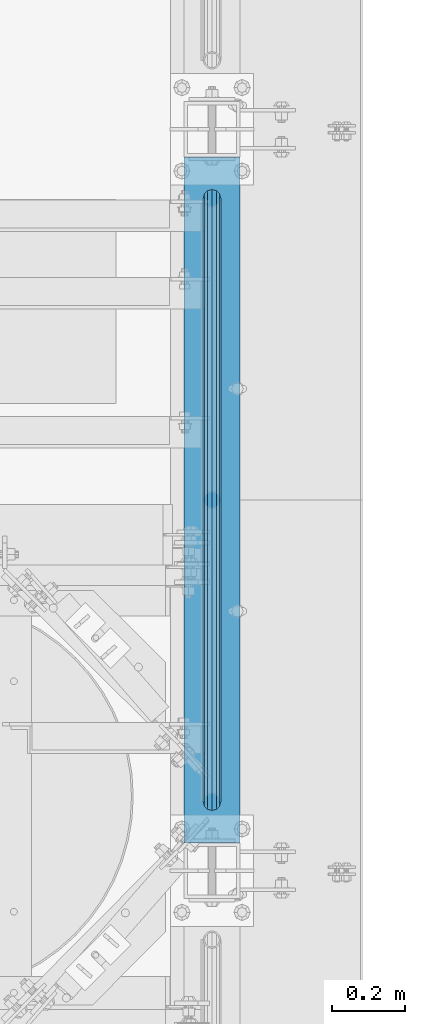
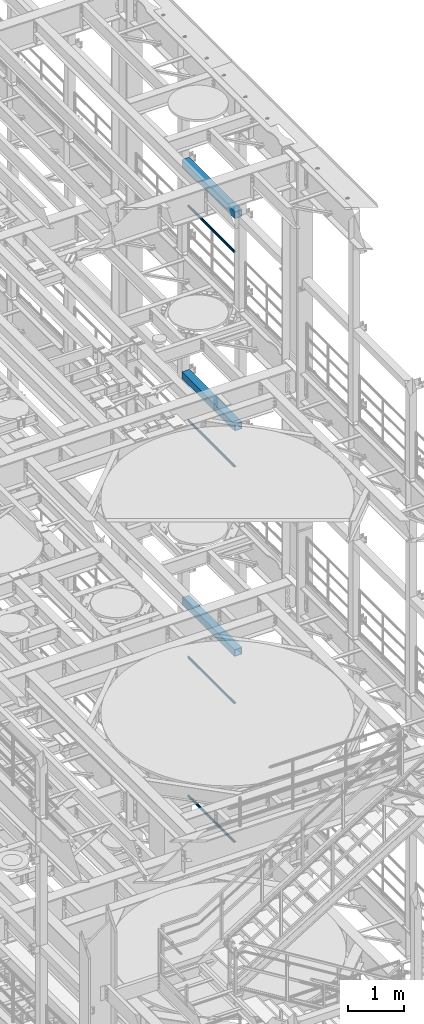
# One storey, part 1037 of 1876: 7 beams, 7 elements without a shape of their own.
"""IFC2X3 building model written with IfcOpenShell, lengths in millimetres."""

from ifc_helpers import new_model, si_unit, frame, origin_with_axes, place, context, subcontext, project, spatial, faceted_brep, material, type_object, element, aggregate, save


model = new_model("IFC2X3")

# Units and contexts
model_context = context("Model", 3, precision=1e-05, world=origin_with_axes())
body_context = subcontext(model_context, "Body", "Model", "MODEL_VIEW")
ifc_project = project(units=[si_unit("LENGTHUNIT", "METRE", prefix="MILLI"), si_unit("AREAUNIT", "SQUARE_METRE"), si_unit("VOLUMEUNIT", "CUBIC_METRE"), si_unit("MASSUNIT", "GRAM", prefix="KILO"), si_unit("TIMEUNIT", "SECOND"), si_unit("PLANEANGLEUNIT", "RADIAN"), si_unit("SOLIDANGLEUNIT", "STERADIAN"), si_unit("THERMODYNAMICTEMPERATUREUNIT", "DEGREE_CELSIUS"), si_unit("LUMINOUSINTENSITYUNIT", "LUMEN")], contexts=[model_context])

# Site, building, storey
site_placement = place(None, origin_with_axes())
site = spatial("IfcSite", under=ifc_project, at=site_placement, CompositionType="ELEMENT")
building_placement = place(site_placement, origin_with_axes())
building = spatial("IfcBuilding", under=site, at=building_placement, Name="Undefined", CompositionType="ELEMENT")
storey_placement = place(building_placement, origin_with_axes())
storey = spatial("IfcBuildingStorey", under=building, at=storey_placement, Name="Undefined", CompositionType="ELEMENT", Elevation=0.0)

# Assembly, beam
assembly_1_placement = place(storey_placement, origin_with_axes())
assembly_1 = element("IfcElementAssembly", 1, at=assembly_1_placement, inside=storey, Name="RAIL", AssemblyPlace="NOTDEFINED", PredefinedType="RIGID_FRAME")
ifc_material_1 = material()
beam_type_1 = type_object("IfcBeamType", Name="PIPE1-1/2SCH40", PredefinedType="NOTDEFINED")
beam_1_placement = place(assembly_1_placement, frame((7620.0, 3721.1, 19059.525), z_axis=(0.0, 0.0, -1.0), x_axis=(0.0, 1.0, 0.0)))
beam_1 = element("IfcBeam", 2, at=beam_1_placement, type_object=beam_type_1, material=ifc_material_1, Name="RAIL", ObjectType="PIPE1-1/2SCH40", context=body_context, shape_type="Brep", body=[
    faceted_brep([(24.1300000000001, -20.4469999999999, 0.0), (34.3535000000002, -17.7076214311803, 10.2235000000001), (1667.4465, -17.7076214311801, 10.2235000000001), (1677.67, -20.4470000000001, 0.0), (41.8376214311802, -10.2235000000001, 17.7076214311819), (1659.96237856882, -10.2235000000001, 17.7076214311819), (44.5770000000002, 0.0, 20.4470000000001), (1657.223, 0.0, 20.4470000000001), (41.8376214311802, 10.2235000000001, 17.7076214311819), (1659.96237856882, 10.2235000000001, 17.7076214311819), (34.3535000000002, 17.7076214311803, 10.2235000000001), (1667.4465, 17.7076214311801, 10.2235000000001), (24.1300000000001, 20.4469999999999, 0.0), (1677.67, 20.4470000000001, 0.0), (13.9065000000001, 17.7076214311803, -10.2235000000001), (1687.8935, 17.7076214311801, -10.2235000000001), (6.42237856882002, 10.2235000000001, -17.7076214311819), (1695.37762143118, 10.2235000000001, -17.7076214311819), (3.68299999999999, 0.0, -20.4470000000001), (1698.117, 0.0, -20.4470000000001), (6.42237856882002, -10.2235000000001, -17.7076214311819), (1695.37762143118, -10.2235000000001, -17.7076214311819), (13.9065000000001, -17.7076214311803, -10.2235000000001), (1687.8935, -17.7076214311801, -10.2235000000001), (24.1299999999854, -24.1299999999992, 0.0), (12.0650000000064, -20.8971929933177, -12.0649999999987), (1689.735, -20.8971929933186, -12.0649999999987), (1677.67, -24.1300000000001, 0.0), (3.23280700668147, -12.0650000000001, -20.8971929933177), (1698.56719299332, -12.0649999999996, -20.8971929933177), (-1.45519152283669e-11, 0.0, -24.130000000001), (1701.8, 0.0, -24.130000000001), (3.23280700668147, 12.0650000000001, -20.8971929933177), (1698.56719299332, 12.0649999999996, -20.8971929933177), (12.0650000000064, 20.8971929933177, -12.0649999999987), (1689.735, 20.8971929933186, -12.0649999999987), (24.1300000000047, 24.1299999999992, 0.0), (1677.67, 24.1300000000001, 0.0), (36.1949999999997, 20.8971929933184, 12.0649999999987), (1665.605, 20.8971929933186, 12.0649999999987), (45.0271929933187, 12.0650000000001, 20.8971929933177), (1656.77280700668, 12.0649999999996, 20.8971929933177), (48.2600000000002, 0.0, 24.130000000001), (1653.54, 0.0, 24.130000000001), (45.0271929933187, -12.0650000000001, 20.8971929933177), (1656.77280700668, -12.0649999999996, 20.8971929933177), (36.1949999999997, -20.8971929933184, 12.0649999999987), (1665.605, -20.8971929933186, 12.0649999999987)], [[[0, 1, 2, 3]], [[1, 4, 5, 2]], [[4, 6, 7, 5]], [[6, 8, 9, 7]], [[8, 10, 11, 9]], [[10, 12, 13, 11]], [[12, 14, 15, 13]], [[14, 16, 17, 15]], [[16, 18, 19, 17]], [[18, 20, 21, 19]], [[20, 22, 23, 21]], [[22, 0, 3, 23]], [[24, 25, 26, 27]], [[25, 28, 29, 26]], [[28, 30, 31, 29]], [[30, 32, 33, 31]], [[32, 34, 35, 33]], [[34, 36, 37, 35]], [[36, 38, 39, 37]], [[38, 40, 41, 39]], [[40, 42, 43, 41]], [[42, 44, 45, 43]], [[44, 46, 47, 45]], [[46, 24, 27, 47]], [[29, 31, 33, 35, 37, 39, 41, 43, 45, 47, 27, 26], [5, 7, 9, 11, 13, 15, 17, 19, 21, 23, 3, 2]], [[46, 44, 42, 40, 38, 36, 34, 32, 30, 28, 25, 24], [22, 20, 18, 16, 14, 12, 10, 8, 6, 4, 1, 0]]]),
])
aggregate(assembly_1, [beam_1])

assembly_2_placement = place(storey_placement, origin_with_axes())
assembly_2 = element("IfcElementAssembly", 3, at=assembly_2_placement, inside=storey, Name="RAIL", AssemblyPlace="NOTDEFINED", PredefinedType="RIGID_FRAME")
beam_2_placement = place(assembly_2_placement, frame((7620.0, 3721.1, 14385.925), z_axis=(0.0, 0.0, -1.0), x_axis=(0.0, 1.0, 0.0)))
beam_2 = element("IfcBeam", 4, at=beam_2_placement, type_object=beam_type_1, material=ifc_material_1, Name="RAIL", ObjectType="PIPE1-1/2SCH40", context=body_context, shape_type="Brep", body=[
    faceted_brep([(24.1300000000001, -20.4469999999999, 0.0), (34.3535000000002, -17.7076214311803, 10.2235000000001), (1667.4465, -17.7076214311801, 10.2235000000001), (1677.67, -20.4470000000001, 0.0), (41.8376214311802, -10.2235000000001, 17.7076214311819), (1659.96237856882, -10.2235000000001, 17.7076214311819), (44.5770000000002, 0.0, 20.4470000000001), (1657.223, 0.0, 20.4470000000001), (41.8376214311802, 10.2235000000001, 17.7076214311819), (1659.96237856882, 10.2235000000001, 17.7076214311819), (34.3535000000002, 17.7076214311803, 10.2235000000001), (1667.4465, 17.7076214311801, 10.2235000000001), (24.1300000000001, 20.4469999999999, 0.0), (1677.67, 20.4470000000001, 0.0), (13.9065000000001, 17.7076214311803, -10.2235000000001), (1687.8935, 17.7076214311801, -10.2235000000001), (6.42237856882002, 10.2235000000001, -17.7076214311819), (1695.37762143118, 10.2235000000001, -17.7076214311819), (3.68299999999999, 0.0, -20.4470000000001), (1698.117, 0.0, -20.4470000000001), (6.42237856882002, -10.2235000000001, -17.7076214311819), (1695.37762143118, -10.2235000000001, -17.7076214311819), (13.9065000000001, -17.7076214311803, -10.2235000000001), (1687.8935, -17.7076214311801, -10.2235000000001), (24.1299999999854, -24.1299999999992, 0.0), (12.0650000000064, -20.8971929933177, -12.0649999999987), (1689.735, -20.8971929933186, -12.0649999999987), (1677.67, -24.1300000000001, 0.0), (3.23280700668147, -12.0650000000001, -20.8971929933177), (1698.56719299332, -12.0649999999996, -20.8971929933177), (-1.45519152283669e-11, 0.0, -24.130000000001), (1701.8, 0.0, -24.130000000001), (3.23280700668147, 12.0650000000001, -20.8971929933177), (1698.56719299332, 12.0649999999996, -20.8971929933177), (12.0650000000064, 20.8971929933177, -12.0649999999987), (1689.735, 20.8971929933186, -12.0649999999987), (24.1300000000047, 24.1299999999992, 0.0), (1677.67, 24.1300000000001, 0.0), (36.1949999999997, 20.8971929933184, 12.0649999999987), (1665.605, 20.8971929933186, 12.0649999999987), (45.0271929933187, 12.0650000000001, 20.8971929933177), (1656.77280700668, 12.0649999999996, 20.8971929933177), (48.2600000000002, 0.0, 24.130000000001), (1653.54, 0.0, 24.130000000001), (45.0271929933187, -12.0650000000001, 20.8971929933177), (1656.77280700668, -12.0649999999996, 20.8971929933177), (36.1949999999997, -20.8971929933184, 12.0649999999987), (1665.605, -20.8971929933186, 12.0649999999987)], [[[0, 1, 2, 3]], [[1, 4, 5, 2]], [[4, 6, 7, 5]], [[6, 8, 9, 7]], [[8, 10, 11, 9]], [[10, 12, 13, 11]], [[12, 14, 15, 13]], [[14, 16, 17, 15]], [[16, 18, 19, 17]], [[18, 20, 21, 19]], [[20, 22, 23, 21]], [[22, 0, 3, 23]], [[24, 25, 26, 27]], [[25, 28, 29, 26]], [[28, 30, 31, 29]], [[30, 32, 33, 31]], [[32, 34, 35, 33]], [[34, 36, 37, 35]], [[36, 38, 39, 37]], [[38, 40, 41, 39]], [[40, 42, 43, 41]], [[42, 44, 45, 43]], [[44, 46, 47, 45]], [[46, 24, 27, 47]], [[29, 31, 33, 35, 37, 39, 41, 43, 45, 47, 27, 26], [5, 7, 9, 11, 13, 15, 17, 19, 21, 23, 3, 2]], [[46, 44, 42, 40, 38, 36, 34, 32, 30, 28, 25, 24], [22, 20, 18, 16, 14, 12, 10, 8, 6, 4, 1, 0]]]),
])
aggregate(assembly_2, [beam_2])

assembly_3_placement = place(storey_placement, origin_with_axes())
assembly_3 = element("IfcElementAssembly", 5, at=assembly_3_placement, inside=storey, Name="RAIL", AssemblyPlace="NOTDEFINED", PredefinedType="RIGID_FRAME")
beam_3_placement = place(assembly_3_placement, frame((7620.0, 3721.1, 9229.725), z_axis=(0.0, 0.0, -1.0), x_axis=(0.0, 1.0, 0.0)))
beam_3 = element("IfcBeam", 6, at=beam_3_placement, type_object=beam_type_1, material=ifc_material_1, Name="RAIL", ObjectType="PIPE1-1/2SCH40", context=body_context, shape_type="Brep", body=[
    faceted_brep([(24.1300000000001, -20.4469999999999, 0.0), (34.3535000000002, -17.7076214311803, 10.2235000000001), (1667.4465, -17.7076214311801, 10.2235000000001), (1677.67, -20.4470000000001, 0.0), (41.8376214311802, -10.2235000000001, 17.7076214311819), (1659.96237856882, -10.2235000000001, 17.7076214311819), (44.5770000000002, 0.0, 20.4470000000001), (1657.223, 0.0, 20.4470000000001), (41.8376214311802, 10.2235000000001, 17.7076214311819), (1659.96237856882, 10.2235000000001, 17.7076214311819), (34.3535000000002, 17.7076214311803, 10.2235000000001), (1667.4465, 17.7076214311801, 10.2235000000001), (24.1300000000001, 20.4469999999999, 0.0), (1677.67, 20.4470000000001, 0.0), (13.9065000000001, 17.7076214311803, -10.2235000000001), (1687.8935, 17.7076214311801, -10.2235000000001), (6.42237856882002, 10.2235000000001, -17.7076214311819), (1695.37762143118, 10.2235000000001, -17.7076214311819), (3.68299999999999, 0.0, -20.4470000000001), (1698.117, 0.0, -20.4470000000001), (6.42237856882002, -10.2235000000001, -17.7076214311819), (1695.37762143118, -10.2235000000001, -17.7076214311819), (13.9065000000001, -17.7076214311803, -10.2235000000001), (1687.8935, -17.7076214311801, -10.2235000000001), (24.1299999999854, -24.1299999999992, 0.0), (12.0650000000064, -20.8971929933177, -12.0649999999987), (1689.735, -20.8971929933186, -12.0649999999987), (1677.67, -24.1300000000001, 0.0), (3.23280700668147, -12.0650000000001, -20.8971929933177), (1698.56719299332, -12.0649999999996, -20.8971929933177), (-1.45519152283669e-11, 0.0, -24.130000000001), (1701.8, 0.0, -24.130000000001), (3.23280700668147, 12.0650000000001, -20.8971929933177), (1698.56719299332, 12.0649999999996, -20.8971929933177), (12.0650000000064, 20.8971929933177, -12.0649999999987), (1689.735, 20.8971929933186, -12.0649999999987), (24.1300000000047, 24.1299999999992, 0.0), (1677.67, 24.1300000000001, 0.0), (36.1949999999997, 20.8971929933184, 12.0649999999987), (1665.605, 20.8971929933186, 12.0649999999987), (45.0271929933187, 12.0650000000001, 20.8971929933177), (1656.77280700668, 12.0649999999996, 20.8971929933177), (48.2600000000002, 0.0, 24.130000000001), (1653.54, 0.0, 24.130000000001), (45.0271929933187, -12.0650000000001, 20.8971929933177), (1656.77280700668, -12.0649999999996, 20.8971929933177), (36.1949999999997, -20.8971929933184, 12.0649999999987), (1665.605, -20.8971929933186, 12.0649999999987)], [[[0, 1, 2, 3]], [[1, 4, 5, 2]], [[4, 6, 7, 5]], [[6, 8, 9, 7]], [[8, 10, 11, 9]], [[10, 12, 13, 11]], [[12, 14, 15, 13]], [[14, 16, 17, 15]], [[16, 18, 19, 17]], [[18, 20, 21, 19]], [[20, 22, 23, 21]], [[22, 0, 3, 23]], [[24, 25, 26, 27]], [[25, 28, 29, 26]], [[28, 30, 31, 29]], [[30, 32, 33, 31]], [[32, 34, 35, 33]], [[34, 36, 37, 35]], [[36, 38, 39, 37]], [[38, 40, 41, 39]], [[40, 42, 43, 41]], [[42, 44, 45, 43]], [[44, 46, 47, 45]], [[46, 24, 27, 47]], [[29, 31, 33, 35, 37, 39, 41, 43, 45, 47, 27, 26], [5, 7, 9, 11, 13, 15, 17, 19, 21, 23, 3, 2]], [[46, 44, 42, 40, 38, 36, 34, 32, 30, 28, 25, 24], [22, 20, 18, 16, 14, 12, 10, 8, 6, 4, 1, 0]]]),
])
aggregate(assembly_3, [beam_3])

assembly_4_placement = place(storey_placement, origin_with_axes())
assembly_4 = element("IfcElementAssembly", 7, at=assembly_4_placement, inside=storey, Name="RAIL", AssemblyPlace="NOTDEFINED", PredefinedType="RIGID_FRAME")
beam_4_placement = place(assembly_4_placement, frame((7620.0, 3721.1, 6207.125), z_axis=(0.0, 0.0, -1.0), x_axis=(0.0, 1.0, 0.0)))
beam_4 = element("IfcBeam", 8, at=beam_4_placement, type_object=beam_type_1, material=ifc_material_1, Name="RAIL", ObjectType="PIPE1-1/2SCH40", context=body_context, shape_type="Brep", body=[
    faceted_brep([(24.1300000000001, -20.4469999999999, 0.0), (34.3535000000002, -17.7076214311803, 10.2235000000001), (1667.4465, -17.7076214311801, 10.2235000000001), (1677.67, -20.4470000000001, 0.0), (41.8376214311802, -10.2235000000001, 17.7076214311819), (1659.96237856882, -10.2235000000001, 17.7076214311819), (44.5770000000002, 0.0, 20.4470000000001), (1657.223, 0.0, 20.4470000000001), (41.8376214311802, 10.2235000000001, 17.7076214311819), (1659.96237856882, 10.2235000000001, 17.7076214311819), (34.3535000000002, 17.7076214311803, 10.2235000000001), (1667.4465, 17.7076214311801, 10.2235000000001), (24.1300000000001, 20.4469999999999, 0.0), (1677.67, 20.4470000000001, 0.0), (13.9065000000001, 17.7076214311803, -10.2235000000001), (1687.8935, 17.7076214311801, -10.2235000000001), (6.42237856882002, 10.2235000000001, -17.7076214311819), (1695.37762143118, 10.2235000000001, -17.7076214311819), (3.68299999999999, 0.0, -20.4470000000001), (1698.117, 0.0, -20.4470000000001), (6.42237856882002, -10.2235000000001, -17.7076214311819), (1695.37762143118, -10.2235000000001, -17.7076214311819), (13.9065000000001, -17.7076214311803, -10.2235000000001), (1687.8935, -17.7076214311801, -10.2235000000001), (24.1299999999854, -24.1299999999992, 0.0), (12.0650000000064, -20.8971929933177, -12.0649999999987), (1689.735, -20.8971929933186, -12.0649999999987), (1677.67, -24.1300000000001, 0.0), (3.23280700668147, -12.0650000000001, -20.8971929933177), (1698.56719299332, -12.0649999999996, -20.8971929933177), (-1.45519152283669e-11, 0.0, -24.130000000001), (1701.8, 0.0, -24.130000000001), (3.23280700668147, 12.0650000000001, -20.8971929933177), (1698.56719299332, 12.0649999999996, -20.8971929933177), (12.0650000000064, 20.8971929933177, -12.0649999999987), (1689.735, 20.8971929933186, -12.0649999999987), (24.1300000000047, 24.1299999999992, 0.0), (1677.67, 24.1300000000001, 0.0), (36.1949999999997, 20.8971929933184, 12.0649999999987), (1665.605, 20.8971929933186, 12.0649999999987), (45.0271929933187, 12.0650000000001, 20.8971929933177), (1656.77280700668, 12.0649999999996, 20.8971929933177), (48.2600000000002, 0.0, 24.130000000001), (1653.54, 0.0, 24.130000000001), (45.0271929933187, -12.0650000000001, 20.8971929933177), (1656.77280700668, -12.0649999999996, 20.8971929933177), (36.1949999999997, -20.8971929933184, 12.0649999999987), (1665.605, -20.8971929933186, 12.0649999999987)], [[[0, 1, 2, 3]], [[1, 4, 5, 2]], [[4, 6, 7, 5]], [[6, 8, 9, 7]], [[8, 10, 11, 9]], [[10, 12, 13, 11]], [[12, 14, 15, 13]], [[14, 16, 17, 15]], [[16, 18, 19, 17]], [[18, 20, 21, 19]], [[20, 22, 23, 21]], [[22, 0, 3, 23]], [[24, 25, 26, 27]], [[25, 28, 29, 26]], [[28, 30, 31, 29]], [[30, 32, 33, 31]], [[32, 34, 35, 33]], [[34, 36, 37, 35]], [[36, 38, 39, 37]], [[38, 40, 41, 39]], [[40, 42, 43, 41]], [[42, 44, 45, 43]], [[44, 46, 47, 45]], [[46, 24, 27, 47]], [[29, 31, 33, 35, 37, 39, 41, 43, 45, 47, 27, 26], [5, 7, 9, 11, 13, 15, 17, 19, 21, 23, 3, 2]], [[46, 44, 42, 40, 38, 36, 34, 32, 30, 28, 25, 24], [22, 20, 18, 16, 14, 12, 10, 8, 6, 4, 1, 0]]]),
])
aggregate(assembly_4, [beam_4])

assembly_5_placement = place(storey_placement, origin_with_axes())
assembly_5 = element("IfcElementAssembly", 9, at=assembly_5_placement, inside=storey, Name="BEAM", AssemblyPlace="NOTDEFINED", PredefinedType="RIGID_FRAME")
ifc_material_2 = material()
beam_type_2 = type_object("IfcBeamType", Name="HSS6X6X3/8", PredefinedType="NOTDEFINED")
beam_5_placement = place(assembly_5_placement, frame((7620.0, 3556.0, 19958.05), z_axis=(-1.0, 0.0, 0.0), x_axis=(0.0, 1.0, 0.0)))
beam_5 = element("IfcBeam", 10, at=beam_5_placement, type_object=beam_type_2, material=ifc_material_2, Name="BEAM", ObjectType="HSS6X6X3/8", context=body_context, shape_type="Brep", body=[
    faceted_brep([(76.2000000000007, 66.6749999999993, -66.6750000000002), (76.2000000000007, -66.6749999999993, -66.6750000000002), (1955.8, -66.6749999999993, -66.675), (1955.8, 66.6749999999993, -66.675), (76.2000000000007, -66.6749999999993, 66.6750000000002), (1955.8, -66.6749999999993, 66.675), (76.2000000000007, 66.6749999999993, 66.6750000000002), (1955.8, 66.6749999999993, 66.675), (76.2000000000007, 76.2000000000007, -76.1999999999998), (76.2000000000007, 76.2000000000007, 76.1999999999998), (1955.8, 76.2000000000007, 76.2), (1955.8, 76.2000000000007, -76.2), (76.2000000000007, -76.2000000000007, 76.1999999999998), (1955.8, -76.2000000000007, 76.2), (76.2000000000007, -76.2000000000007, -76.1999999999998), (1955.8, -76.2000000000007, -76.2)], [[[0, 1, 2, 3]], [[1, 4, 5, 2]], [[4, 6, 7, 5]], [[6, 0, 3, 7]], [[8, 9, 10, 11]], [[9, 12, 13, 10]], [[12, 14, 15, 13]], [[14, 8, 11, 15]], [[13, 15, 11, 10], [5, 7, 3, 2]], [[14, 12, 9, 8], [6, 4, 1, 0]]]),
])
aggregate(assembly_5, [beam_5])

assembly_6_placement = place(storey_placement, origin_with_axes())
assembly_6 = element("IfcElementAssembly", 11, at=assembly_6_placement, inside=storey, Name="BEAM", AssemblyPlace="NOTDEFINED", PredefinedType="RIGID_FRAME")
beam_6_placement = place(assembly_6_placement, frame((7620.0, 3556.0, 15335.25), z_axis=(-1.0, 0.0, 0.0), x_axis=(0.0, 1.0, 0.0)))
beam_6 = element("IfcBeam", 12, at=beam_6_placement, type_object=beam_type_2, material=ifc_material_2, Name="BEAM", ObjectType="HSS6X6X3/8", context=body_context, shape_type="Brep", body=[
    faceted_brep([(76.2000000000007, 66.6749999999993, -66.6750000000002), (76.2000000000007, -66.6749999999993, -66.6750000000002), (1955.8, -66.6749999999993, -66.675), (1955.8, 66.6749999999993, -66.675), (76.2000000000007, -66.6749999999993, 66.6750000000002), (1955.8, -66.6749999999993, 66.675), (76.2000000000007, 66.6749999999993, 66.6750000000002), (1955.8, 66.6749999999993, 66.675), (76.2000000000007, 76.2000000000007, -76.1999999999998), (76.2000000000007, 76.2000000000007, 76.1999999999998), (1955.8, 76.2000000000007, 76.2), (1955.8, 76.2000000000007, -76.2), (76.2000000000007, -76.2000000000007, 76.1999999999998), (1955.8, -76.2000000000007, 76.2), (76.2000000000007, -76.2000000000007, -76.1999999999998), (1955.8, -76.2000000000007, -76.2)], [[[0, 1, 2, 3]], [[1, 4, 5, 2]], [[4, 6, 7, 5]], [[6, 0, 3, 7]], [[8, 9, 10, 11]], [[9, 12, 13, 10]], [[12, 14, 15, 13]], [[14, 8, 11, 15]], [[13, 15, 11, 10], [5, 7, 3, 2]], [[14, 12, 9, 8], [6, 4, 1, 0]]]),
])
aggregate(assembly_6, [beam_6])

assembly_7_placement = place(storey_placement, origin_with_axes())
assembly_7 = element("IfcElementAssembly", 13, at=assembly_7_placement, inside=storey, Name="BEAM", AssemblyPlace="NOTDEFINED", PredefinedType="RIGID_FRAME")
beam_7_placement = place(assembly_7_placement, frame((7620.0, 3556.0, 10420.35), z_axis=(-1.0, 0.0, 0.0), x_axis=(0.0, 1.0, 0.0)))
beam_7 = element("IfcBeam", 14, at=beam_7_placement, type_object=beam_type_2, material=ifc_material_2, Name="BEAM", ObjectType="HSS6X6X3/8", context=body_context, shape_type="Brep", body=[
    faceted_brep([(76.2000000000007, 66.6749999999993, -66.6750000000002), (76.2000000000007, -66.6749999999993, -66.6750000000002), (1955.8, -66.6749999999993, -66.675), (1955.8, 66.6749999999993, -66.675), (76.2000000000007, -66.6749999999993, 66.6750000000002), (1955.8, -66.6749999999993, 66.675), (76.2000000000007, 66.6749999999993, 66.6750000000002), (1955.8, 66.6749999999993, 66.675), (76.2000000000007, 76.2000000000007, -76.1999999999998), (76.2000000000007, 76.2000000000007, 76.1999999999998), (1955.8, 76.2000000000007, 76.2), (1955.8, 76.2000000000007, -76.2), (76.2000000000007, -76.2000000000007, 76.1999999999998), (1955.8, -76.2000000000007, 76.2), (76.2000000000007, -76.2000000000007, -76.1999999999998), (1955.8, -76.2000000000007, -76.2)], [[[0, 1, 2, 3]], [[1, 4, 5, 2]], [[4, 6, 7, 5]], [[6, 0, 3, 7]], [[8, 9, 10, 11]], [[9, 12, 13, 10]], [[12, 14, 15, 13]], [[14, 8, 11, 15]], [[13, 15, 11, 10], [5, 7, 3, 2]], [[14, 12, 9, 8], [6, 4, 1, 0]]]),
])
aggregate(assembly_7, [beam_7])

save(model, "model.ifc")
